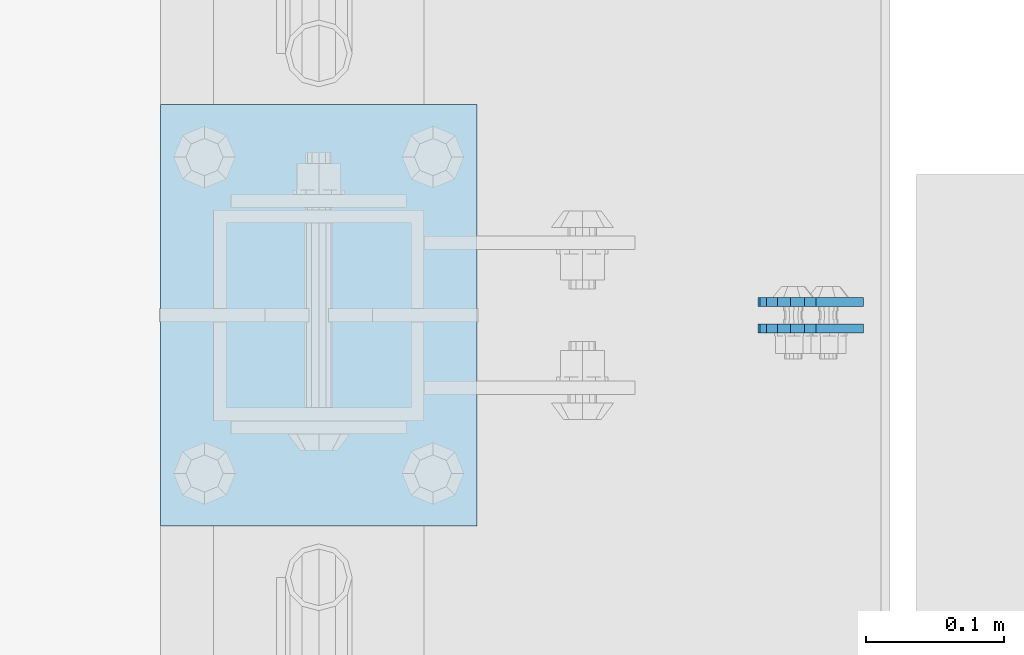
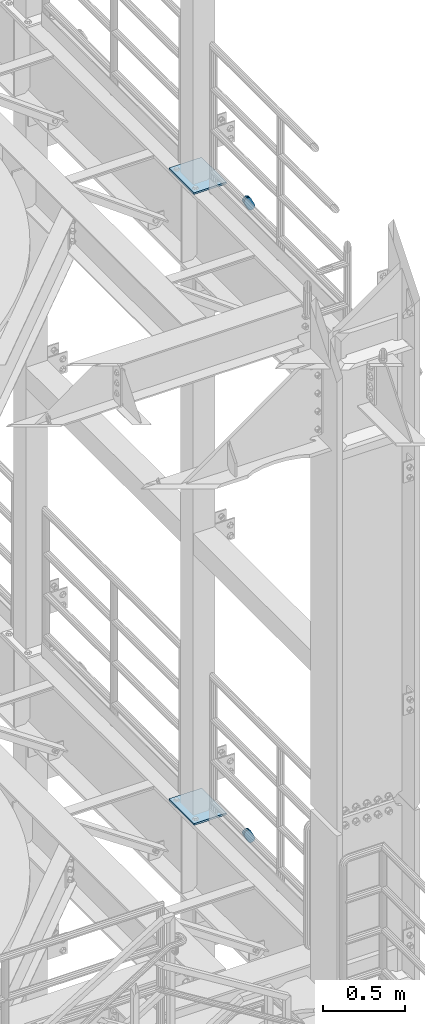
# One storey, part 1528 of 1876: 6 plates, 6 elements without a shape of their own.
"""IFC2X3 building model written with IfcOpenShell, lengths in millimetres."""

from ifc_helpers import new_model, si_unit, frame, origin_with_axes, place, context, subcontext, project, spatial, faceted_brep, material, type_object, element, aggregate, save


model = new_model("IFC2X3")

# Units and contexts
model_context = context("Model", 3, precision=1e-05, world=origin_with_axes())
body_context = subcontext(model_context, "Body", "Model", "MODEL_VIEW")
ifc_project = project(units=[si_unit("LENGTHUNIT", "METRE", prefix="MILLI"), si_unit("AREAUNIT", "SQUARE_METRE"), si_unit("VOLUMEUNIT", "CUBIC_METRE"), si_unit("MASSUNIT", "GRAM", prefix="KILO"), si_unit("TIMEUNIT", "SECOND"), si_unit("PLANEANGLEUNIT", "RADIAN"), si_unit("SOLIDANGLEUNIT", "STERADIAN"), si_unit("THERMODYNAMICTEMPERATUREUNIT", "DEGREE_CELSIUS"), si_unit("LUMINOUSINTENSITYUNIT", "LUMEN")], contexts=[model_context])

# Site, building, storey
site_placement = place(None, origin_with_axes())
site = spatial("IfcSite", under=ifc_project, at=site_placement, CompositionType="ELEMENT")
building_placement = place(site_placement, origin_with_axes())
building = spatial("IfcBuilding", under=site, at=building_placement, Name="Undefined", CompositionType="ELEMENT")
storey_placement = place(building_placement, origin_with_axes())
storey = spatial("IfcBuildingStorey", under=building, at=storey_placement, Name="Undefined", CompositionType="ELEMENT", Elevation=0.0)

# Assembly, plate
assembly_1_placement = place(storey_placement, origin_with_axes())
assembly_1 = element("IfcElementAssembly", 1, at=assembly_1_placement, inside=storey, Name="PLATE", AssemblyPlace="NOTDEFINED", PredefinedType="RIGID_FRAME")
ifc_material = material(Name="STEEL/A36")
plate_type_1 = type_object("IfcPlateType", PredefinedType="NOTDEFINED")
plate_1_placement = place(assembly_1_placement, frame((7974.1626510523, -2549.52499463594, 17725.1776774809), z_axis=(-0.894427191199917, 1.49999996210681e-08, -0.447213595099955), x_axis=(0.447213595099955, -6.99999707257281e-09, -0.894427191199917)))
plate_1 = element("IfcPlate", 2, at=plate_1_placement, type_object=plate_type_1, material=ifc_material, Name="PLATE", context=body_context, shape_type="Brep", body=[
    faceted_brep([(-8.59611645864788e-07, -3.17499999999654, 25.3999987589127), (1.93345873884391, -3.17499999999382, 35.1201580589886), (1.93345873884391, 3.17500000000564, 35.1201580589886), (-8.59611645864788e-07, 3.17500000000382, 25.3999987589132), (7.43948648259902, -3.17499999999109, 43.3605112870105), (7.43948648259902, 3.17500000000928, 43.3605112870105), (15.6798395242777, -3.17499999998654, 48.8665393096448), (15.6798395242777, 3.17500000001382, 48.8665393096448), (25.3999987589095, -3.17499999998199, 50.7999992370592), (25.3999987589095, 3.17500000001837, 50.7999992370592), (82.196130752618, -3.17499999998381, 50.7999992370605), (82.196130752618, 3.17500000001655, 50.7999992370642), (91.9162897887145, -3.17499999997926, 48.8665393918873), (91.9162897887145, 3.1750000000211, 48.8665393918909), (100.156642725027, -3.17499999997472, 43.3605115909359), (100.156642725027, 3.17500000002565, 43.3605115909395), (105.662670525982, -3.17499999997108, 35.1201586546285), (105.662670525986, 3.17500000002929, 35.1201586546358), (107.596130371159, -3.17499999996744, 25.3999996185757), (107.596130371159, 3.17500000003292, 25.3999996185794), (105.662670525981, -3.17499999996471, 15.6798405824902), (105.662670525981, 3.17500000003565, 15.6798405824939), (100.156642725024, -3.17499999996471, 7.43948764618654), (100.156642725025, 3.17500000003565, 7.43948764619017), (91.9162897887127, -3.17499999996562, 1.93345984522784), (91.9162897887127, 3.17500000003474, 1.93345984523148), (82.196130752618, -3.17499999996835, 4.54747350886464e-11), (82.196130752618, 3.1750000000311, 4.91127138957381e-11), (25.399998758905, -3.17499999999018, -8.64019966684282e-12), (25.399998758905, 3.17500000001019, -8.64019966684282e-12), (15.679839921364, -3.17499999999382, 1.9334597629304), (15.679839921364, 3.17500000000655, 1.9334597629304), (7.43948709043525, -3.17499999999654, 7.43948734220839), (7.43948709043525, 3.17500000000382, 7.43948734220885), (1.93345923228208, -3.17499999999654, 15.6798399868012), (1.93345923228208, 3.17500000000291, 15.6798399868012)], [[[0, 1, 2, 3]], [[1, 4, 5, 2]], [[4, 6, 7, 5]], [[6, 8, 9, 7]], [[8, 10, 11, 9]], [[10, 12, 13, 11]], [[12, 14, 15, 13]], [[14, 16, 17, 15]], [[16, 18, 19, 17]], [[18, 20, 21, 19]], [[20, 22, 23, 21]], [[22, 24, 25, 23]], [[24, 26, 27, 25]], [[26, 28, 29, 27]], [[28, 30, 31, 29]], [[30, 32, 33, 31]], [[32, 34, 35, 33]], [[34, 0, 3, 35]], [[5, 7, 9, 11, 13, 15, 17, 19, 21, 23, 25, 27, 29, 31, 33, 35, 3, 2]], [[34, 32, 30, 28, 26, 24, 22, 20, 18, 16, 14, 12, 10, 8, 6, 4, 1, 0]]]),
])
aggregate(assembly_1, [plate_1])

assembly_2_placement = place(storey_placement, origin_with_axes())
assembly_2 = element("IfcElementAssembly", 3, at=assembly_2_placement, inside=storey, Name="PLATE", AssemblyPlace="NOTDEFINED", PredefinedType="RIGID_FRAME")
plate_2_placement = place(assembly_2_placement, frame((7974.16265164888, -2530.46379833126, 17725.1776774809), z_axis=(-0.894427191199917, 1.49999996210681e-08, -0.447213595099955), x_axis=(0.447213595099955, -6.99999707257281e-09, -0.894427191199917)))
plate_2 = element("IfcPlate", 4, at=plate_2_placement, type_object=plate_type_1, material=ifc_material, Name="PLATE", context=body_context, shape_type="Brep", body=[
    faceted_brep([(-8.59611645864788e-07, -3.17499999999654, 25.3999987589127), (1.93345873884391, -3.17499999999382, 35.1201580589886), (1.93345873884391, 3.17500000000564, 35.1201580589886), (-8.59611645864788e-07, 3.17500000000382, 25.3999987589132), (7.43948648259902, -3.17499999999109, 43.3605112870105), (7.43948648259902, 3.17500000000928, 43.3605112870105), (15.6798395242777, -3.17499999998654, 48.8665393096448), (15.6798395242777, 3.17500000001382, 48.8665393096448), (25.3999987589095, -3.17499999998199, 50.7999992370592), (25.3999987589095, 3.17500000001837, 50.7999992370592), (82.196130752618, -3.17499999998381, 50.7999992370605), (82.196130752618, 3.17500000001655, 50.7999992370642), (91.9162897887145, -3.17499999997926, 48.8665393918873), (91.9162897887145, 3.1750000000211, 48.8665393918909), (100.156642725027, -3.17499999997472, 43.3605115909359), (100.156642725027, 3.17500000002565, 43.3605115909395), (105.662670525982, -3.17499999997108, 35.1201586546285), (105.662670525986, 3.17500000002929, 35.1201586546358), (107.596130371159, -3.17499999996744, 25.3999996185757), (107.596130371159, 3.17500000003292, 25.3999996185794), (105.662670525981, -3.17499999996471, 15.6798405824902), (105.662670525981, 3.17500000003565, 15.6798405824939), (100.156642725024, -3.17499999996471, 7.43948764618654), (100.156642725025, 3.17500000003565, 7.43948764619017), (91.9162897887127, -3.17499999996562, 1.93345984522784), (91.9162897887127, 3.17500000003474, 1.93345984523148), (82.196130752618, -3.17499999996835, 4.54747350886464e-11), (82.196130752618, 3.1750000000311, 4.91127138957381e-11), (25.399998758905, -3.17499999999018, -8.64019966684282e-12), (25.399998758905, 3.17500000001019, -8.64019966684282e-12), (15.679839921364, -3.17499999999382, 1.9334597629304), (15.679839921364, 3.17500000000655, 1.9334597629304), (7.43948709043525, -3.17499999999654, 7.43948734220839), (7.43948709043525, 3.17500000000382, 7.43948734220885), (1.93345923228208, -3.17499999999654, 15.6798399868012), (1.93345923228208, 3.17500000000291, 15.6798399868012)], [[[0, 1, 2, 3]], [[1, 4, 5, 2]], [[4, 6, 7, 5]], [[6, 8, 9, 7]], [[8, 10, 11, 9]], [[10, 12, 13, 11]], [[12, 14, 15, 13]], [[14, 16, 17, 15]], [[16, 18, 19, 17]], [[18, 20, 21, 19]], [[20, 22, 23, 21]], [[22, 24, 25, 23]], [[24, 26, 27, 25]], [[26, 28, 29, 27]], [[28, 30, 31, 29]], [[30, 32, 33, 31]], [[32, 34, 35, 33]], [[34, 0, 3, 35]], [[5, 7, 9, 11, 13, 15, 17, 19, 21, 23, 25, 27, 29, 31, 33, 35, 3, 2]], [[34, 32, 30, 28, 26, 24, 22, 20, 18, 16, 14, 12, 10, 8, 6, 4, 1, 0]]]),
])
aggregate(assembly_2, [plate_2])

assembly_3_placement = place(storey_placement, origin_with_axes())
assembly_3 = element("IfcElementAssembly", 5, at=assembly_3_placement, inside=storey, Name="PLATE", AssemblyPlace="NOTDEFINED", PredefinedType="RIGID_FRAME")
plate_3_placement = place(assembly_3_placement, frame((7974.1626510523, -2549.52499463594, 13038.877677481), z_axis=(-0.894427191199917, 1.49999996210681e-08, -0.447213595099955), x_axis=(0.447213595099955, -6.99999707257281e-09, -0.894427191199917)))
plate_3 = element("IfcPlate", 6, at=plate_3_placement, type_object=plate_type_1, material=ifc_material, Name="PLATE", context=body_context, shape_type="Brep", body=[
    faceted_brep([(-8.59611645864788e-07, -3.17499999999654, 25.3999987589127), (1.93345873884391, -3.17499999999382, 35.1201580589886), (1.93345873884391, 3.17500000000564, 35.1201580589886), (-8.59611645864788e-07, 3.17500000000382, 25.3999987589132), (7.43948648259902, -3.17499999999109, 43.3605112870105), (7.43948648259902, 3.17500000000928, 43.3605112870105), (15.6798395242777, -3.17499999998654, 48.8665393096448), (15.6798395242777, 3.17500000001382, 48.8665393096448), (25.3999987589095, -3.17499999998199, 50.7999992370592), (25.3999987589095, 3.17500000001837, 50.7999992370592), (82.196130752618, -3.17499999998381, 50.7999992370605), (82.196130752618, 3.17500000001655, 50.7999992370642), (91.9162897887145, -3.17499999997926, 48.8665393918873), (91.9162897887145, 3.1750000000211, 48.8665393918909), (100.156642725027, -3.17499999997472, 43.3605115909359), (100.156642725027, 3.17500000002565, 43.3605115909395), (105.662670525982, -3.17499999997108, 35.1201586546285), (105.662670525986, 3.17500000002929, 35.1201586546358), (107.596130371159, -3.17499999996744, 25.3999996185757), (107.596130371159, 3.17500000003292, 25.3999996185794), (105.662670525981, -3.17499999996471, 15.6798405824902), (105.662670525981, 3.17500000003565, 15.6798405824939), (100.156642725024, -3.17499999996471, 7.43948764618654), (100.156642725025, 3.17500000003565, 7.43948764619017), (91.9162897887127, -3.17499999996562, 1.93345984522784), (91.9162897887127, 3.17500000003474, 1.93345984523148), (82.196130752618, -3.17499999996835, 4.54747350886464e-11), (82.196130752618, 3.1750000000311, 4.91127138957381e-11), (25.399998758905, -3.17499999999018, -8.64019966684282e-12), (25.399998758905, 3.17500000001019, -8.64019966684282e-12), (15.679839921364, -3.17499999999382, 1.9334597629304), (15.679839921364, 3.17500000000655, 1.9334597629304), (7.43948709043525, -3.17499999999654, 7.43948734220839), (7.43948709043525, 3.17500000000382, 7.43948734220885), (1.93345923228208, -3.17499999999654, 15.6798399868012), (1.93345923228208, 3.17500000000291, 15.6798399868012)], [[[0, 1, 2, 3]], [[1, 4, 5, 2]], [[4, 6, 7, 5]], [[6, 8, 9, 7]], [[8, 10, 11, 9]], [[10, 12, 13, 11]], [[12, 14, 15, 13]], [[14, 16, 17, 15]], [[16, 18, 19, 17]], [[18, 20, 21, 19]], [[20, 22, 23, 21]], [[22, 24, 25, 23]], [[24, 26, 27, 25]], [[26, 28, 29, 27]], [[28, 30, 31, 29]], [[30, 32, 33, 31]], [[32, 34, 35, 33]], [[34, 0, 3, 35]], [[5, 7, 9, 11, 13, 15, 17, 19, 21, 23, 25, 27, 29, 31, 33, 35, 3, 2]], [[34, 32, 30, 28, 26, 24, 22, 20, 18, 16, 14, 12, 10, 8, 6, 4, 1, 0]]]),
])
aggregate(assembly_3, [plate_3])

assembly_4_placement = place(storey_placement, origin_with_axes())
assembly_4 = element("IfcElementAssembly", 7, at=assembly_4_placement, inside=storey, Name="PLATE", AssemblyPlace="NOTDEFINED", PredefinedType="RIGID_FRAME")
plate_4_placement = place(assembly_4_placement, frame((7974.16265164888, -2530.46379833126, 13038.877677481), z_axis=(-0.894427191199917, 1.49999996210681e-08, -0.447213595099955), x_axis=(0.447213595099955, -6.99999707257281e-09, -0.894427191199917)))
plate_4 = element("IfcPlate", 8, at=plate_4_placement, type_object=plate_type_1, material=ifc_material, Name="PLATE", context=body_context, shape_type="Brep", body=[
    faceted_brep([(-8.59611645864788e-07, -3.17499999999654, 25.3999987589127), (1.93345873884391, -3.17499999999382, 35.1201580589886), (1.93345873884391, 3.17500000000564, 35.1201580589886), (-8.59611645864788e-07, 3.17500000000382, 25.3999987589132), (7.43948648259902, -3.17499999999109, 43.3605112870105), (7.43948648259902, 3.17500000000928, 43.3605112870105), (15.6798395242777, -3.17499999998654, 48.8665393096448), (15.6798395242777, 3.17500000001382, 48.8665393096448), (25.3999987589095, -3.17499999998199, 50.7999992370592), (25.3999987589095, 3.17500000001837, 50.7999992370592), (82.196130752618, -3.17499999998381, 50.7999992370605), (82.196130752618, 3.17500000001655, 50.7999992370642), (91.9162897887145, -3.17499999997926, 48.8665393918873), (91.9162897887145, 3.1750000000211, 48.8665393918909), (100.156642725027, -3.17499999997472, 43.3605115909359), (100.156642725027, 3.17500000002565, 43.3605115909395), (105.662670525982, -3.17499999997108, 35.1201586546285), (105.662670525986, 3.17500000002929, 35.1201586546358), (107.596130371159, -3.17499999996744, 25.3999996185757), (107.596130371159, 3.17500000003292, 25.3999996185794), (105.662670525981, -3.17499999996471, 15.6798405824902), (105.662670525981, 3.17500000003565, 15.6798405824939), (100.156642725024, -3.17499999996471, 7.43948764618654), (100.156642725025, 3.17500000003565, 7.43948764619017), (91.9162897887127, -3.17499999996562, 1.93345984522784), (91.9162897887127, 3.17500000003474, 1.93345984523148), (82.196130752618, -3.17499999996835, 4.54747350886464e-11), (82.196130752618, 3.1750000000311, 4.91127138957381e-11), (25.399998758905, -3.17499999999018, -8.64019966684282e-12), (25.399998758905, 3.17500000001019, -8.64019966684282e-12), (15.679839921364, -3.17499999999382, 1.9334597629304), (15.679839921364, 3.17500000000655, 1.9334597629304), (7.43948709043525, -3.17499999999654, 7.43948734220839), (7.43948709043525, 3.17500000000382, 7.43948734220885), (1.93345923228208, -3.17499999999654, 15.6798399868012), (1.93345923228208, 3.17500000000291, 15.6798399868012)], [[[0, 1, 2, 3]], [[1, 4, 5, 2]], [[4, 6, 7, 5]], [[6, 8, 9, 7]], [[8, 10, 11, 9]], [[10, 12, 13, 11]], [[12, 14, 15, 13]], [[14, 16, 17, 15]], [[16, 18, 19, 17]], [[18, 20, 21, 19]], [[20, 22, 23, 21]], [[22, 24, 25, 23]], [[24, 26, 27, 25]], [[26, 28, 29, 27]], [[28, 30, 31, 29]], [[30, 32, 33, 31]], [[32, 34, 35, 33]], [[34, 0, 3, 35]], [[5, 7, 9, 11, 13, 15, 17, 19, 21, 23, 25, 27, 29, 31, 33, 35, 3, 2]], [[34, 32, 30, 28, 26, 24, 22, 20, 18, 16, 14, 12, 10, 8, 6, 4, 1, 0]]]),
])
aggregate(assembly_4, [plate_4])

assembly_5_placement = place(storey_placement, origin_with_axes())
assembly_5 = element("IfcElementAssembly", 9, at=assembly_5_placement, inside=storey, Name="BEAM", AssemblyPlace="NOTDEFINED", PredefinedType="RIGID_FRAME")
plate_type_2 = type_object("IfcPlateType", PredefinedType="NOTDEFINED")
plate_5_placement = place(assembly_5_placement, frame((7505.7, -2692.4, 17989.55), z_axis=(0.0, 1.0, 0.0), x_axis=(1.0, 0.0, 0.0)))
plate_5 = element("IfcPlate", 10, at=plate_5_placement, type_object=plate_type_2, material=ifc_material, Name="PLATE", context=body_context, shape_type="Brep", body=[
    faceted_brep([(0.0, -6.35000000000036, 0.0), (0.0, -6.35000000000036, 304.799987792969), (0.0, 6.35000000000036, 304.799987792969), (0.0, 6.35000000000036, 0.0), (228.600006103516, -6.34999999999854, 304.799987792969), (228.600006103516, 6.34999999999854, 304.799987792969), (228.600006103516, -6.34999999999854, 0.0), (228.600006103516, 6.34999999999854, 0.0)], [[[0, 1, 2, 3]], [[1, 4, 5, 2]], [[4, 6, 7, 5]], [[6, 0, 3, 7]], [[5, 7, 3, 2]], [[6, 4, 1, 0]]]),
])
aggregate(assembly_5, [plate_5])

assembly_6_placement = place(storey_placement, origin_with_axes())
assembly_6 = element("IfcElementAssembly", 11, at=assembly_6_placement, inside=storey, Name="BEAM", AssemblyPlace="NOTDEFINED", PredefinedType="RIGID_FRAME")
plate_6_placement = place(assembly_6_placement, frame((7505.7, -2692.4, 13315.95), z_axis=(0.0, 1.0, 0.0), x_axis=(1.0, 0.0, 0.0)))
plate_6 = element("IfcPlate", 12, at=plate_6_placement, type_object=plate_type_2, material=ifc_material, Name="PLATE", context=body_context, shape_type="Brep", body=[
    faceted_brep([(0.0, -6.35000000000036, 0.0), (0.0, -6.35000000000036, 304.799987792969), (0.0, 6.35000000000036, 304.799987792969), (0.0, 6.35000000000036, 0.0), (228.600006103516, -6.34999999999854, 304.799987792969), (228.600006103516, 6.34999999999854, 304.799987792969), (228.600006103516, -6.34999999999854, 0.0), (228.600006103516, 6.34999999999854, 0.0)], [[[0, 1, 2, 3]], [[1, 4, 5, 2]], [[4, 6, 7, 5]], [[6, 0, 3, 7]], [[5, 7, 3, 2]], [[6, 4, 1, 0]]]),
])
aggregate(assembly_6, [plate_6])

save(model, "model.ifc")
